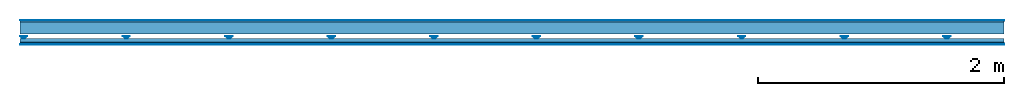
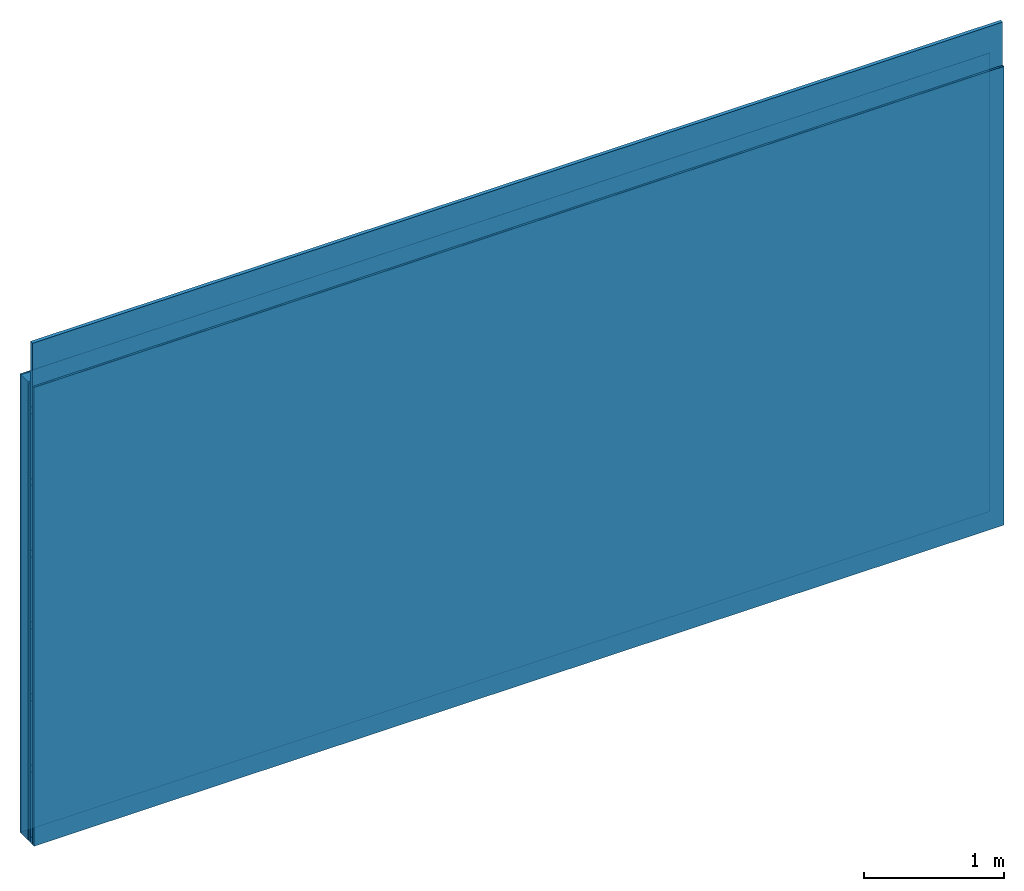
# One storey: 4 members, 4 plates, 1 element without a shape of its own.
"""IFC4 building model written with IfcOpenShell, lengths in metres."""

from ifc_helpers import new_model, si_unit, derived_unit, direction, frame, frame_2d, origin, origin_with_axes, place, context, project, spatial, polyline, rectangle, outline, extrude, material, layer, layer_set, type_object, element, aggregate, save


model = new_model("IFC4")

# Units and contexts
plan_context = context("Plan", 3, precision=1e-05, world=origin(), true_north=direction((0.0, 1.0)))
model_context = context("Model", 3, precision=1e-05, world=origin(), true_north=direction((0.0, 1.0)))
ifc_project = project(units=[si_unit("LENGTHUNIT", "METRE"), derived_unit("SOUNDPRESSUREUNIT", [(si_unit("PRESSUREUNIT", "PASCAL", prefix="MICRO"), 0)]), si_unit("ENERGYUNIT", "JOULE", prefix="MEGA"), si_unit("MASSUNIT", "GRAM", prefix="KILO"), derived_unit("THERMALTRANSMITTANCEUNIT", [(si_unit("POWERUNIT", "WATT"), 1), (si_unit("AREAUNIT", "SQUARE_METRE"), -1), (si_unit("THERMODYNAMICTEMPERATUREUNIT", "KELVIN"), -1)]), derived_unit("AREADENSITYUNIT", [(si_unit("MASSUNIT", "GRAM", prefix="KILO"), 1), (si_unit("AREAUNIT", "SQUARE_METRE"), -1)]), derived_unit("USERDEFINED", [(si_unit("ENERGYUNIT", "JOULE", prefix="MEGA"), 1), (si_unit("AREAUNIT", "SQUARE_METRE"), -1)])], contexts=[plan_context, model_context])

# Site, building, storey
site = spatial("IfcSite", under=ifc_project)
building_placement = place(None, origin())
building = spatial("IfcBuilding", under=site, at=building_placement)
storey_placement = place(building_placement, origin())
storey = spatial("IfcBuildingStorey", under=building, at=storey_placement)

# Wall, members, plates
ifc_material_1 = material(Category="04.001")
ifc_layer_1 = layer(ifc_material_1, 0.003, Name="Surface")
ifc_material_2 = material(Name="Plasterboard type A", Category="03.008")
ifc_layer_2 = layer(ifc_material_2, 0.0125, Name="1st layer")
ifc_material_3 = material(Name="of the art")
ifc_layer_3 = layer(ifc_material_3, 0.0, Name="Bond")
ifc_layer_4 = layer(None, 0.1, Name="Support")
ifc_layer_5 = layer(None, 0.036, Name="Coupling")
ifc_layer_6 = layer(None, 0.03, Name="Battens / profiles")
ifc_material_4 = material(Name="DFH2IR Knauf Diamant hard- plasterboard", Category="03.007")
ifc_layer_7 = layer(ifc_material_4, 0.015, Name="Covering 1st layer")
ifc_layer_8 = layer(ifc_material_1, 0.003, Name="Surface")
ifc_layer_set = layer_set([ifc_layer_1, ifc_layer_2, ifc_layer_3, ifc_layer_4, ifc_layer_5, ifc_layer_6, ifc_layer_7, ifc_layer_8])
wall_type = type_object("IfcWallType", Name="C0376", PredefinedType="NOTDEFINED", material=ifc_layer_set)
wall_placement = place(None, frame((0.0, 0.0, 0.0), z_axis=(0.0, -1.0, 0.0), x_axis=(1.0, 0.0, 0.0)))
wall = element("IfcWall", 1, at=wall_placement, inside=storey, type_object=wall_type, material=ifc_layer_set, Name="Wall #1")
ifc_material_5 = material(Name="Solid timber panel")
member_1_placement = place(wall_placement, origin())
member_1 = element("IfcMember", 2, at=member_1_placement, material=ifc_material_5, Name="Support", context=plan_context, shape_type="SweptSolid", body=[
    extrude(rectangle(XDim=1.0, YDim=0.1, at=frame_2d((0.5, 0.05), x_axis=(1.0, 0.0))), frame((0.0, 4.0, 0.0155), z_axis=(0.0, -1.0, 0.0), x_axis=(1.0, 0.0, 0.0)), (0.0, 0.0, 1.0), 4.0),
    extrude(rectangle(XDim=1.0, YDim=0.1, at=frame_2d((0.5, 0.05), x_axis=(1.0, 0.0))), frame((1.0, 4.0, 0.0155), z_axis=(0.0, -1.0, 0.0), x_axis=(1.0, 0.0, 0.0)), (0.0, 0.0, 1.0), 4.0),
    extrude(rectangle(XDim=1.0, YDim=0.1, at=frame_2d((0.5, 0.05), x_axis=(1.0, 0.0))), frame((2.0, 4.0, 0.0155), z_axis=(0.0, -1.0, 0.0), x_axis=(1.0, 0.0, 0.0)), (0.0, 0.0, 1.0), 4.0),
    extrude(rectangle(XDim=1.0, YDim=0.1, at=frame_2d((0.5, 0.05), x_axis=(1.0, 0.0))), frame((3.0, 4.0, 0.0155), z_axis=(0.0, -1.0, 0.0), x_axis=(1.0, 0.0, 0.0)), (0.0, 0.0, 1.0), 4.0),
    extrude(rectangle(XDim=1.0, YDim=0.1, at=frame_2d((0.5, 0.05), x_axis=(1.0, 0.0))), frame((4.0, 4.0, 0.0155), z_axis=(0.0, -1.0, 0.0), x_axis=(1.0, 0.0, 0.0)), (0.0, 0.0, 1.0), 4.0),
    extrude(rectangle(XDim=1.0, YDim=0.1, at=frame_2d((0.5, 0.05), x_axis=(1.0, 0.0))), frame((5.0, 4.0, 0.0155), z_axis=(0.0, -1.0, 0.0), x_axis=(1.0, 0.0, 0.0)), (0.0, 0.0, 1.0), 4.0),
    extrude(rectangle(XDim=1.0, YDim=0.1, at=frame_2d((0.5, 0.05), x_axis=(1.0, 0.0))), frame((6.0, 4.0, 0.0155), z_axis=(0.0, -1.0, 0.0), x_axis=(1.0, 0.0, 0.0)), (0.0, 0.0, 1.0), 4.0),
    extrude(rectangle(XDim=1.0, YDim=0.1, at=frame_2d((0.5, 0.05), x_axis=(1.0, 0.0))), frame((7.0, 4.0, 0.0155), z_axis=(0.0, -1.0, 0.0), x_axis=(1.0, 0.0, 0.0)), (0.0, 0.0, 1.0), 4.0),
])
ifc_material_6 = material()
member_2_placement = place(wall_placement, origin())
member_2 = element("IfcMember", 3, at=member_2_placement, material=ifc_material_6, Name="Coupling", context=plan_context, shape_type="SweptSolid", body=[
    extrude(outline(polyline([(0.0, 0.0), (0.06, 0.0), (0.04, 0.02), (0.02, 0.02), (0.0, 0.0)])), frame((0.0, 4.0, 0.1315), z_axis=(0.0, -1.0, 0.0), x_axis=(1.0, 0.0, 0.0)), (0.0, 0.0, 1.0), 4.0),
    extrude(outline(polyline([(0.0, 0.0), (0.06, 0.0), (0.04, 0.02), (0.02, 0.02), (0.0, 0.0)])), frame((0.834, 4.0, 0.1315), z_axis=(0.0, -1.0, 0.0), x_axis=(1.0, 0.0, 0.0)), (0.0, 0.0, 1.0), 4.0),
    extrude(outline(polyline([(0.0, 0.0), (0.06, 0.0), (0.04, 0.02), (0.02, 0.02), (0.0, 0.0)])), frame((1.668, 4.0, 0.1315), z_axis=(0.0, -1.0, 0.0), x_axis=(1.0, 0.0, 0.0)), (0.0, 0.0, 1.0), 4.0),
    extrude(outline(polyline([(0.0, 0.0), (0.06, 0.0), (0.04, 0.02), (0.02, 0.02), (0.0, 0.0)])), frame((2.502, 4.0, 0.1315), z_axis=(0.0, -1.0, 0.0), x_axis=(1.0, 0.0, 0.0)), (0.0, 0.0, 1.0), 4.0),
    extrude(outline(polyline([(0.0, 0.0), (0.06, 0.0), (0.04, 0.02), (0.02, 0.02), (0.0, 0.0)])), frame((3.336, 4.0, 0.1315), z_axis=(0.0, -1.0, 0.0), x_axis=(1.0, 0.0, 0.0)), (0.0, 0.0, 1.0), 4.0),
    extrude(outline(polyline([(0.0, 0.0), (0.06, 0.0), (0.04, 0.02), (0.02, 0.02), (0.0, 0.0)])), frame((4.17, 4.0, 0.1315), z_axis=(0.0, -1.0, 0.0), x_axis=(1.0, 0.0, 0.0)), (0.0, 0.0, 1.0), 4.0),
    extrude(outline(polyline([(0.0, 0.0), (0.06, 0.0), (0.04, 0.02), (0.02, 0.02), (0.0, 0.0)])), frame((5.004, 4.0, 0.1315), z_axis=(0.0, -1.0, 0.0), x_axis=(1.0, 0.0, 0.0)), (0.0, 0.0, 1.0), 4.0),
    extrude(outline(polyline([(0.0, 0.0), (0.06, 0.0), (0.04, 0.02), (0.02, 0.02), (0.0, 0.0)])), frame((5.838, 4.0, 0.1315), z_axis=(0.0, -1.0, 0.0), x_axis=(1.0, 0.0, 0.0)), (0.0, 0.0, 1.0), 4.0),
    extrude(outline(polyline([(0.0, 0.0), (0.06, 0.0), (0.04, 0.02), (0.02, 0.02), (0.0, 0.0)])), frame((6.672, 4.0, 0.1315), z_axis=(0.0, -1.0, 0.0), x_axis=(1.0, 0.0, 0.0)), (0.0, 0.0, 1.0), 4.0),
    extrude(outline(polyline([(0.0, 0.0), (0.06, 0.0), (0.04, 0.02), (0.02, 0.02), (0.0, 0.0)])), frame((7.506, 4.0, 0.1315), z_axis=(0.0, -1.0, 0.0), x_axis=(1.0, 0.0, 0.0)), (0.0, 0.0, 1.0), 4.0),
])
member_3_placement = place(wall_placement, origin())
member_3 = element("IfcMember", 4, at=member_3_placement, material=ifc_material_6, Name="Battens / profiles", context=plan_context, shape_type="SweptSolid", body=[
    extrude(rectangle(XDim=0.06, YDim=0.03, at=frame_2d((0.03, 0.015), x_axis=(1.0, 0.0))), frame((0.0, 0.0, 0.1515), z_axis=(1.0, 0.0, 0.0), x_axis=(0.0, 1.0, 0.0)), (0.0, 0.0, 1.0), 8.0),
    extrude(rectangle(XDim=0.06, YDim=0.03, at=frame_2d((0.03, 0.015), x_axis=(1.0, 0.0))), frame((0.0, 0.625, 0.1515), z_axis=(1.0, 0.0, 0.0), x_axis=(0.0, 1.0, 0.0)), (0.0, 0.0, 1.0), 8.0),
    extrude(rectangle(XDim=0.06, YDim=0.03, at=frame_2d((0.03, 0.015), x_axis=(1.0, 0.0))), frame((0.0, 1.25, 0.1515), z_axis=(1.0, 0.0, 0.0), x_axis=(0.0, 1.0, 0.0)), (0.0, 0.0, 1.0), 8.0),
    extrude(rectangle(XDim=0.06, YDim=0.03, at=frame_2d((0.03, 0.015), x_axis=(1.0, 0.0))), frame((0.0, 1.875, 0.1515), z_axis=(1.0, 0.0, 0.0), x_axis=(0.0, 1.0, 0.0)), (0.0, 0.0, 1.0), 8.0),
    extrude(rectangle(XDim=0.06, YDim=0.03, at=frame_2d((0.03, 0.015), x_axis=(1.0, 0.0))), frame((0.0, 2.5, 0.1515), z_axis=(1.0, 0.0, 0.0), x_axis=(0.0, 1.0, 0.0)), (0.0, 0.0, 1.0), 8.0),
    extrude(rectangle(XDim=0.06, YDim=0.03, at=frame_2d((0.03, 0.015), x_axis=(1.0, 0.0))), frame((0.0, 3.125, 0.1515), z_axis=(1.0, 0.0, 0.0), x_axis=(0.0, 1.0, 0.0)), (0.0, 0.0, 1.0), 8.0),
    extrude(rectangle(XDim=0.06, YDim=0.03, at=frame_2d((0.03, 0.015), x_axis=(1.0, 0.0))), frame((0.0, 3.75, 0.1515), z_axis=(1.0, 0.0, 0.0), x_axis=(0.0, 1.0, 0.0)), (0.0, 0.0, 1.0), 8.0),
])
ifc_material_7 = material()
member_4_placement = place(wall_placement, origin())
member_4 = element("IfcMember", 5, at=member_4_placement, material=ifc_material_7, Name="Cavity", context=plan_context, shape_type="SweptSolid", body=[
    extrude(rectangle(XDim=0.565, YDim=0.03, at=frame_2d((0.2825, 0.015), x_axis=(1.0, 0.0))), frame((0.0, 0.06, 0.1515), z_axis=(1.0, 0.0, 0.0), x_axis=(0.0, 1.0, 0.0)), (0.0, 0.0, 1.0), 8.0),
    extrude(rectangle(XDim=0.565, YDim=0.03, at=frame_2d((0.2825, 0.015), x_axis=(1.0, 0.0))), frame((0.0, 0.685, 0.1515), z_axis=(1.0, 0.0, 0.0), x_axis=(0.0, 1.0, 0.0)), (0.0, 0.0, 1.0), 8.0),
    extrude(rectangle(XDim=0.565, YDim=0.03, at=frame_2d((0.2825, 0.015), x_axis=(1.0, 0.0))), frame((0.0, 1.31, 0.1515), z_axis=(1.0, 0.0, 0.0), x_axis=(0.0, 1.0, 0.0)), (0.0, 0.0, 1.0), 8.0),
    extrude(rectangle(XDim=0.565, YDim=0.03, at=frame_2d((0.2825, 0.015), x_axis=(1.0, 0.0))), frame((0.0, 1.935, 0.1515), z_axis=(1.0, 0.0, 0.0), x_axis=(0.0, 1.0, 0.0)), (0.0, 0.0, 1.0), 8.0),
    extrude(rectangle(XDim=0.565, YDim=0.03, at=frame_2d((0.2825, 0.015), x_axis=(1.0, 0.0))), frame((0.0, 2.56, 0.1515), z_axis=(1.0, 0.0, 0.0), x_axis=(0.0, 1.0, 0.0)), (0.0, 0.0, 1.0), 8.0),
    extrude(rectangle(XDim=0.565, YDim=0.03, at=frame_2d((0.2825, 0.015), x_axis=(1.0, 0.0))), frame((0.0, 3.185, 0.1515), z_axis=(1.0, 0.0, 0.0), x_axis=(0.0, 1.0, 0.0)), (0.0, 0.0, 1.0), 8.0),
    extrude(rectangle(XDim=0.565, YDim=0.03, at=frame_2d((0.2825, 0.015), x_axis=(1.0, 0.0))), frame((0.0, 3.81, 0.1515), z_axis=(1.0, 0.0, 0.0), x_axis=(0.0, 1.0, 0.0)), (0.0, 0.0, 1.0), 8.0),
])
plate_1_placement = place(wall_placement, origin())
plate_1 = element("IfcPlate", 6, at=plate_1_placement, material=ifc_material_1, Name="Surface", context=plan_context, shape_type="SweptSolid", body=[
    extrude(rectangle(XDim=8.0, YDim=4.0, at=frame_2d((4.0, 2.0), x_axis=(1.0, 0.0))), origin_with_axes(), (0.0, 0.0, 1.0), 0.003),
])
plate_2_placement = place(wall_placement, origin())
plate_2 = element("IfcPlate", 7, at=plate_2_placement, material=ifc_material_2, Name="1st layer", context=plan_context, shape_type="SweptSolid", body=[
    extrude(rectangle(XDim=8.0, YDim=4.0, at=frame_2d((4.0, 2.0), x_axis=(1.0, 0.0))), frame((0.0, 0.0, 0.003), z_axis=(0.0, 0.0, 1.0), x_axis=(1.0, 0.0, 0.0)), (0.0, 0.0, 1.0), 0.0125),
])
plate_3_placement = place(wall_placement, origin())
plate_3 = element("IfcPlate", 8, at=plate_3_placement, material=ifc_material_4, Name="Covering 1st layer", context=plan_context, shape_type="SweptSolid", body=[
    extrude(rectangle(XDim=8.0, YDim=4.0, at=frame_2d((4.0, 2.0), x_axis=(1.0, 0.0))), frame((0.0, 0.0, 0.1815), z_axis=(0.0, 0.0, 1.0), x_axis=(1.0, 0.0, 0.0)), (0.0, 0.0, 1.0), 0.015),
])
plate_4_placement = place(wall_placement, origin())
plate_4 = element("IfcPlate", 9, at=plate_4_placement, material=ifc_material_1, Name="Surface", context=plan_context, shape_type="SweptSolid", body=[
    extrude(rectangle(XDim=8.0, YDim=4.0, at=frame_2d((4.0, 2.0), x_axis=(1.0, 0.0))), frame((0.0, 0.0, 0.1965), z_axis=(0.0, 0.0, 1.0), x_axis=(1.0, 0.0, 0.0)), (0.0, 0.0, 1.0), 0.003),
])
aggregate(wall, [plate_1, plate_2, member_1, member_2, member_3, member_4, plate_3, plate_4])

save(model, "model.ifc")
